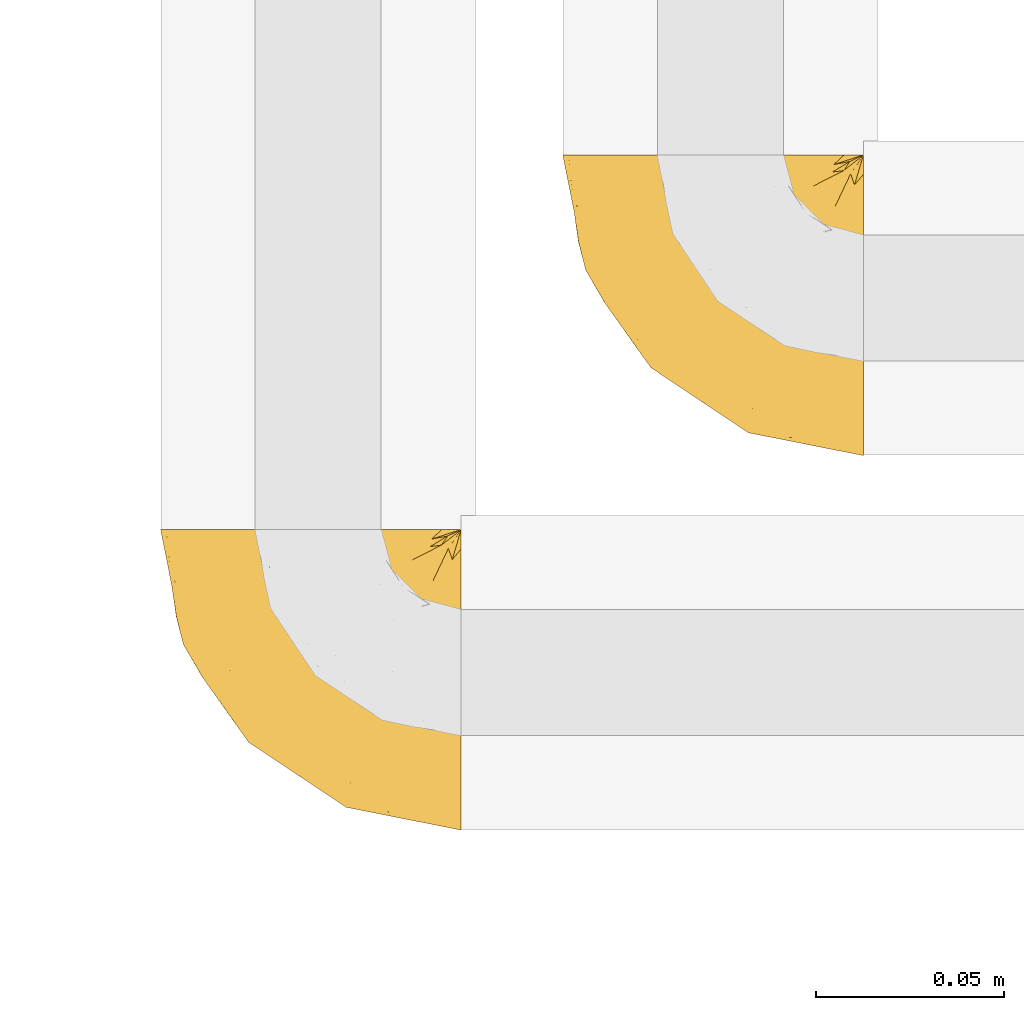
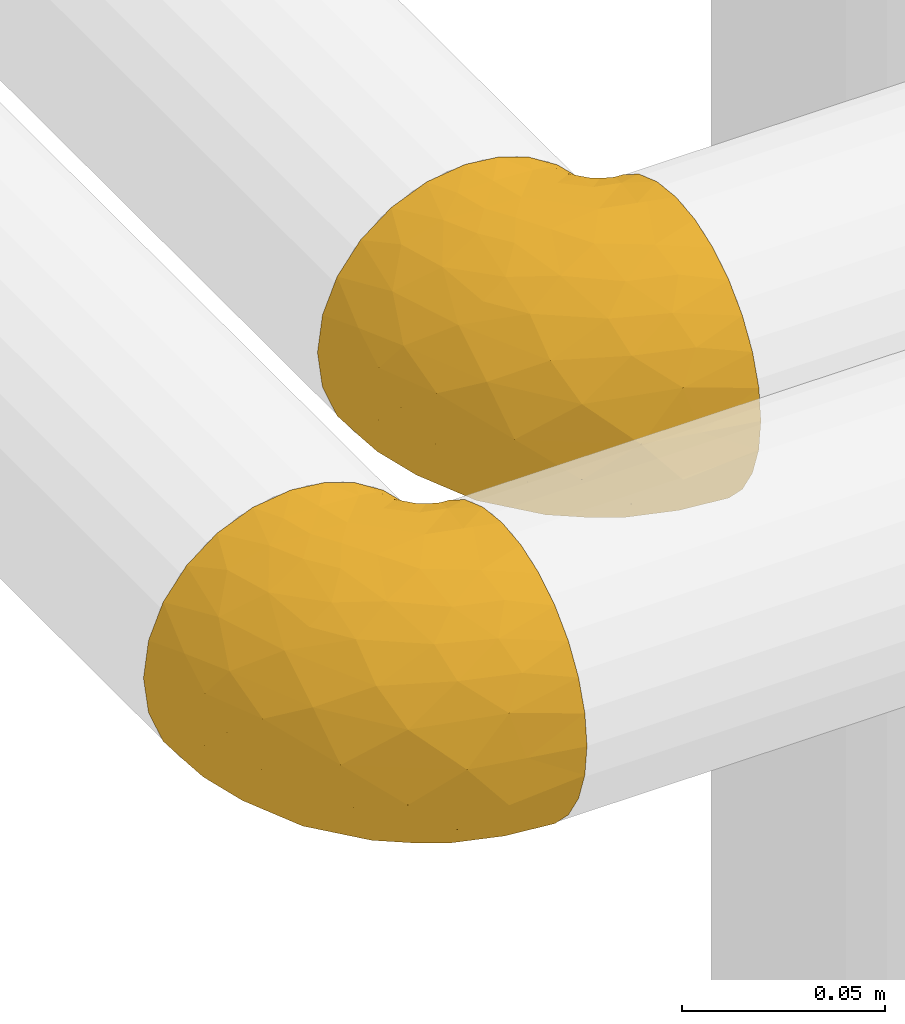
# One storey, part 351 of 827: 2 coverings.
"""IFC2X3 building model written with IfcOpenShell, lengths in millimetres."""

from ifc_helpers import new_model, entity, si_unit, converted_unit, derived_unit, direction, frame, origin, place, context, subcontext, project, spatial, faceted_brep, element, save


model = new_model("IFC2X3")

# Units and contexts
model_context = context("Model", 3, precision=0.01, world=origin(), true_north=direction((6.12303176911189e-17, 1.0)))
body_context = subcontext(model_context, "Body", "Model", "MODEL_VIEW")
ifc_project = project(units=[si_unit("LENGTHUNIT", "METRE", prefix="MILLI"), si_unit("AREAUNIT", "SQUARE_METRE"), si_unit("VOLUMEUNIT", "CUBIC_METRE"), converted_unit("PLANEANGLEUNIT", "DEGREE", entity("IfcRatioMeasure", 0.0174532925199433), si_unit("PLANEANGLEUNIT", "RADIAN"), dimensions=[0, 0, 0, 0, 0, 0, 0]), si_unit("MASSUNIT", "GRAM", prefix="KILO"), derived_unit("MASSDENSITYUNIT", [(si_unit("MASSUNIT", "GRAM", prefix="KILO"), 1), (si_unit("LENGTHUNIT", "METRE"), -3)]), derived_unit("MOMENTOFINERTIAUNIT", [(si_unit("LENGTHUNIT", "METRE"), 4)]), si_unit("TIMEUNIT", "SECOND"), si_unit("FREQUENCYUNIT", "HERTZ"), si_unit("THERMODYNAMICTEMPERATUREUNIT", "DEGREE_CELSIUS"), derived_unit("THERMALTRANSMITTANCEUNIT", [(si_unit("MASSUNIT", "GRAM", prefix="KILO"), 1), (si_unit("THERMODYNAMICTEMPERATUREUNIT", "KELVIN"), -1), (si_unit("TIMEUNIT", "SECOND"), -3)]), derived_unit("VOLUMETRICFLOWRATEUNIT", [(si_unit("LENGTHUNIT", "METRE"), 3), (si_unit("TIMEUNIT", "SECOND"), -1)]), derived_unit("MASSFLOWRATEUNIT", [(si_unit("MASSUNIT", "GRAM", prefix="KILO"), 1), (si_unit("TIMEUNIT", "SECOND"), -1)]), derived_unit("ROTATIONALFREQUENCYUNIT", [(si_unit("TIMEUNIT", "SECOND"), -1)]), si_unit("ELECTRICCURRENTUNIT", "AMPERE"), si_unit("ELECTRICVOLTAGEUNIT", "VOLT"), si_unit("POWERUNIT", "WATT"), si_unit("FORCEUNIT", "NEWTON", prefix="KILO"), si_unit("ILLUMINANCEUNIT", "LUX"), si_unit("LUMINOUSFLUXUNIT", "LUMEN"), si_unit("LUMINOUSINTENSITYUNIT", "CANDELA"), derived_unit("USERDEFINED", [(si_unit("MASSUNIT", "GRAM", prefix="KILO"), -1), (si_unit("LENGTHUNIT", "METRE"), -2), (si_unit("TIMEUNIT", "SECOND"), 3), (si_unit("LUMINOUSFLUXUNIT", "LUMEN"), 1)]), derived_unit("LINEARVELOCITYUNIT", [(si_unit("LENGTHUNIT", "METRE"), 1), (si_unit("TIMEUNIT", "SECOND"), -1)]), si_unit("PRESSUREUNIT", "PASCAL"), derived_unit("USERDEFINED", [(si_unit("LENGTHUNIT", "METRE"), -2), (si_unit("MASSUNIT", "GRAM", prefix="KILO"), 1), (si_unit("TIMEUNIT", "SECOND"), -2)]), derived_unit("LINEARFORCEUNIT", [(si_unit("MASSUNIT", "GRAM", prefix="KILO"), 1), (si_unit("LENGTHUNIT", "METRE"), 1), (si_unit("TIMEUNIT", "SECOND"), -2), (si_unit("LENGTHUNIT", "METRE"), -1)]), derived_unit("PLANARFORCEUNIT", [(si_unit("MASSUNIT", "GRAM", prefix="KILO"), 1), (si_unit("LENGTHUNIT", "METRE"), 1), (si_unit("TIMEUNIT", "SECOND"), -2), (si_unit("LENGTHUNIT", "METRE"), -2)])], contexts=[model_context])

# Site, building, storey
site_placement = place(None, origin())
site = spatial("IfcSite", under=ifc_project, at=site_placement, CompositionType="ELEMENT")
building_placement = place(site_placement, origin())
building = spatial("IfcBuilding", under=site, at=building_placement, CompositionType="ELEMENT")
storey_placement = place(building_placement, frame((0.0, 0.0, 28200.0)))
storey = spatial("IfcBuildingStorey", under=building, at=storey_placement, Name="08", CompositionType="ELEMENT", Elevation=28200.0)

# Coverings
covering_1_placement = place(storey_placement, frame((41432.77, 15288.87, 2956.55)))
element("IfcCovering", 1, at=covering_1_placement, inside=storey, Name=":ADSK_", ObjectType=":ADSK_", PredefinedType="INSULATION", context=body_context, shape_type="Brep", body=[
    faceted_brep([(81.45, 25.28, 81.15), (81.45, 17.35, 76.16), (81.45, 10.72, 69.53), (81.45, 5.74, 61.6), (81.45, 2.64, 52.75), (81.45, 1.6, 43.45), (81.45, 2.65, 34.13), (81.45, 5.74, 25.28), (81.45, 10.73, 17.35), (81.45, 17.36, 10.72), (81.45, 25.29, 5.74), (81.45, 34.14, 2.64), (81.45, 43.45, 1.6), (81.45, 52.82, 2.66), (81.45, 61.71, 5.79), (81.45, 69.67, 10.83), (81.45, 76.31, 17.53), (81.45, 81.27, 25.53), (81.45, 81.27, 26.45), (81.45, 81.27, 27.37), (81.45, 81.27, 28.17), (81.45, 81.27, 29.49), (81.45, 81.27, 30.81), (81.45, 81.27, 32.13), (81.45, 81.27, 33.45), (81.45, 81.27, 34.78), (81.45, 81.27, 36.1), (81.45, 81.27, 37.42), (81.45, 81.27, 38.74), (81.45, 81.27, 40.06), (81.45, 81.27, 41.38), (81.45, 81.27, 42.7), (81.45, 81.27, 44.02), (81.45, 81.27, 45.34), (81.45, 81.27, 46.66), (81.45, 81.27, 47.58), (81.45, 81.27, 48.5), (81.45, 81.27, 49.41), (81.45, 81.27, 50.33), (81.45, 81.27, 51.25), (81.45, 81.27, 52.17), (81.45, 81.27, 53.09), (81.45, 81.27, 54.01), (81.45, 81.27, 54.93), (81.45, 81.27, 55.85), (81.45, 81.27, 56.76), (81.45, 81.27, 57.68), (81.45, 81.27, 58.6), (81.45, 81.27, 59.52), (81.45, 81.27, 60.44), (81.45, 81.27, 61.36), (81.45, 76.3, 69.37), (81.45, 69.66, 76.07), (81.45, 61.69, 81.11), (81.45, 52.8, 84.24), (81.45, 43.45, 85.3), (81.45, 34.13, 84.24), (76.3, 81.45, 17.52), (69.67, 81.45, 10.83), (61.7, 81.45, 5.79), (52.81, 81.45, 2.66), (43.45, 81.45, 1.6), (32.61, 81.45, 3.02), (22.52, 81.45, 7.2), (13.85, 81.45, 13.85), (7.2, 81.45, 22.52), (3.02, 81.45, 32.61), (1.6, 81.45, 43.45), (3.02, 81.45, 54.28), (7.2, 81.45, 64.37), (13.85, 81.45, 73.04), (22.52, 81.45, 79.69), (32.61, 81.45, 83.87), (43.45, 81.45, 85.3), (52.81, 81.45, 84.23), (61.7, 81.45, 81.1), (69.67, 81.45, 76.06), (76.3, 81.45, 69.37), (81.27, 81.45, 61.36), (81.27, 81.45, 60.44), (81.27, 81.45, 59.12), (81.27, 81.45, 58.0), (81.27, 81.45, 56.88), (81.27, 81.45, 55.76), (81.27, 81.45, 54.64), (81.27, 81.45, 53.52), (81.27, 81.45, 52.4), (81.27, 81.45, 51.28), (81.27, 81.45, 50.16), (81.27, 81.45, 49.04), (81.27, 81.45, 47.92), (81.27, 81.45, 46.8), (81.27, 81.45, 45.68), (81.27, 81.45, 44.56), (81.27, 81.45, 43.45), (81.27, 81.45, 42.12), (81.27, 81.45, 40.8), (81.27, 81.45, 39.48), (81.27, 81.45, 38.16), (81.27, 81.45, 36.84), (81.27, 81.45, 35.52), (81.27, 81.45, 34.2), (81.27, 81.45, 32.88), (81.27, 81.45, 31.96), (81.27, 81.45, 31.05), (81.27, 81.45, 30.13), (81.27, 81.45, 29.21), (81.27, 81.45, 28.29), (81.27, 81.45, 27.37), (81.27, 81.45, 26.45), (81.27, 81.45, 25.53), (81.31, 81.33, 54.08), (81.33, 81.32, 55.16), (81.31, 81.33, 36.18), (81.32, 81.32, 35.13), (81.31, 81.33, 44.01), (81.32, 81.32, 45.08), (81.32, 81.32, 61.36), (81.32, 81.32, 59.98), (81.32, 81.32, 46.18), (81.32, 81.32, 26.74), (81.32, 81.32, 47.36), (81.32, 81.32, 29.67), (81.3, 81.34, 28.72), (81.32, 81.32, 39.77), (81.33, 81.31, 52.96), (81.31, 81.33, 51.84), (81.33, 81.31, 40.8), (81.32, 81.32, 41.87), (81.32, 81.33, 42.94), (81.32, 81.32, 27.77), (81.31, 81.33, 48.4), (81.32, 81.32, 37.21), (81.31, 81.33, 33.54), (81.32, 81.32, 32.49), (81.32, 81.32, 30.69), (81.32, 81.32, 50.69), (81.33, 81.31, 49.6), (81.32, 81.32, 56.32), (81.31, 81.33, 57.44), (81.33, 81.31, 58.88), (81.32, 81.32, 25.53), (81.36, 81.3, 61.36), (81.4, 81.29, 61.36), (81.4, 81.29, 25.53), (81.36, 81.3, 25.53), (81.29, 81.4, 61.36), (81.3, 81.36, 61.36), (81.3, 81.36, 25.53), (81.29, 81.4, 25.53), (81.35, 81.3, 31.59), (81.31, 81.33, 38.71), (58.5, 74.06, 3.97), (71.95, 45.99, 1.6), (74.57, 58.35, 3.97), (73.93, 67.76, 8.09), (78.18, 66.18, 8.09), (78.04, 76.46, 16.43), (76.23, 77.33, 15.73), (45.99, 71.95, 1.6), (74.01, 72.25, 10.79), (73.57, 78.91, 13.99), (66.66, 76.42, 8.08), (79.09, 73.52, 14.0), (73.14, 76.9, 12.83), (60.34, 65.25, 3.18), (48.54, 62.45, 1.6), (45.36, 74.31, 1.6), (67.22, 59.38, 3.28), (62.45, 48.54, 1.6), (68.67, 67.72, 6.28), (55.49, 55.49, 1.6), (77.84, 79.73, 19.06), (68.16, 73.23, 8.08), (74.31, 45.36, 1.6), (38.78, 15.81, 32.11), (62.1, 6.4, 29.62), (50.89, 7.67, 43.45), (36.91, 68.46, 2.45), (40.37, 59.33, 2.5), (27.86, 48.7, 9.73), (15.77, 53.94, 17.97), (20.13, 65.02, 10.24), (31.54, 60.77, 4.78), (28.25, 72.07, 4.78), (57.26, 26.25, 8.01), (69.99, 22.29, 8.01), (64.58, 16.0, 13.85), (50.64, 46.93, 2.42), (51.97, 14.19, 21.17), (5.72, 58.46, 35.73), (7.42, 61.51, 27.43), (66.14, 4.64, 43.45), (11.35, 68.93, 17.97), (21.64, 29.62, 35.71), (28.57, 24.85, 29.47), (55.38, 38.55, 3.41), (68.51, 31.27, 3.94), (67.48, 9.35, 21.17), (40.78, 37.15, 7.92), (41.53, 47.07, 4.25), (46.11, 26.49, 11.75), (40.32, 23.01, 18.31), (38.36, 19.4, 24.94), (11.84, 48.06, 28.78), (12.56, 42.46, 35.82), (7.67, 50.89, 43.45), (19.39, 35.78, 28.38), (24.98, 24.98, 43.45), (37.94, 16.33, 43.45), (4.64, 66.14, 43.45), (28.09, 30.96, 21.21), (23.73, 41.83, 16.48), (34.03, 33.28, 13.85), (16.33, 37.94, 43.45), (29.29, 67.39, 82.11), (5.77, 58.47, 51.41), (21.44, 32.5, 57.45), (38.8, 15.79, 54.78), (64.58, 15.99, 73.03), (67.49, 9.34, 65.7), (22.9, 56.91, 76.65), (12.54, 63.5, 68.92), (20.04, 44.08, 68.01), (57.26, 26.24, 78.88), (69.99, 22.27, 78.88), (68.51, 31.26, 82.94), (34.54, 23.95, 64.44), (38.81, 63.79, 84.49), (48.54, 62.45, 85.3), (45.99, 71.95, 85.3), (74.31, 45.36, 85.3), (5.36, 67.83, 57.84), (18.96, 70.28, 76.65), (12.79, 42.11, 51.19), (62.11, 6.39, 57.26), (33.14, 43.54, 78.14), (33.44, 58.03, 82.35), (51.98, 14.18, 65.7), (43.42, 56.34, 84.61), (48.62, 48.09, 84.36), (62.45, 48.54, 85.3), (55.49, 55.49, 85.3), (49.68, 21.78, 73.03), (55.37, 38.54, 83.48), (71.95, 45.99, 85.3), (36.37, 72.79, 84.54), (34.04, 33.26, 73.03), (44.1, 35.53, 79.54), (9.99, 53.66, 59.46), (26.41, 43.03, 73.5), (39.19, 49.68, 82.57), (58.5, 74.06, 82.92), (67.22, 59.37, 83.62), (74.57, 58.34, 82.92), (73.92, 67.75, 78.81), (73.57, 78.91, 72.9), (73.14, 76.9, 74.06), (66.19, 78.08, 78.81), (68.16, 73.23, 78.81), (77.84, 79.73, 67.83), (76.23, 77.34, 71.15), (79.08, 73.51, 72.91), (78.04, 76.45, 70.47), (77.18, 66.41, 78.81), (68.66, 67.7, 80.62), (74.0, 72.24, 76.11), (60.34, 65.25, 83.71)], [[[0, 1, 2, 3, 4, 5, 6, 7, 8, 9, 10, 11, 12, 13, 14, 15, 16, 17, 18, 19, 20, 21, 22, 23, 24, 25, 26, 27, 28, 29, 30, 31, 32, 33, 34, 35, 36, 37, 38, 39, 40, 41, 42, 43, 44, 45, 46, 47, 48, 49, 50, 51, 52, 53, 54, 55, 56]], [[57, 58, 59, 60, 61, 62, 63, 64, 65, 66, 67, 68, 69, 70, 71, 72, 73, 74, 75, 76, 77, 78, 79, 80, 81, 82, 83, 84, 85, 86, 87, 88, 89, 90, 91, 92, 93, 94, 95, 96, 97, 98, 99, 100, 101, 102, 103, 104, 105, 106, 107, 108, 109, 110]], [[111, 84, 112]], [[113, 26, 114]], [[114, 101, 100]], [[115, 93, 116]], [[79, 117, 118]], [[33, 116, 119]], [[117, 49, 118]], [[19, 18, 120]], [[119, 121, 34]], [[122, 21, 123]], [[97, 96, 124]], [[86, 125, 126]], [[116, 92, 119]], [[127, 96, 128]], [[32, 129, 115]], [[19, 120, 130]], [[121, 90, 131]], [[94, 115, 129]], [[115, 116, 32]], [[118, 49, 48]], [[113, 99, 132]], [[133, 114, 25]], [[24, 134, 133]], [[135, 22, 122]], [[136, 137, 88]], [[84, 83, 112]], [[138, 82, 139]], [[130, 20, 19]], [[118, 48, 140]], [[81, 140, 139]], [[123, 21, 20]], [[141, 120, 18]], [[139, 82, 81]], [[130, 107, 123]], [[49, 117, 142, 143, 50]], [[18, 17, 144, 145, 141]], [[79, 78, 146, 147, 117]], [[109, 141, 148, 149, 110]], [[102, 133, 134]], [[105, 135, 122]], [[118, 80, 79]], [[120, 109, 108]], [[80, 118, 140]], [[47, 46, 140, 48]], [[81, 80, 140]], [[44, 112, 138]], [[93, 115, 94]], [[46, 139, 140]], [[46, 45, 139]], [[139, 45, 138]], [[138, 112, 83]], [[85, 84, 111]], [[112, 43, 111]], [[83, 82, 138]], [[106, 122, 123]], [[105, 122, 106]], [[21, 122, 22]], [[124, 29, 28]], [[33, 32, 116]], [[128, 129, 31]], [[32, 31, 129]], [[34, 33, 119]], [[116, 93, 92]], [[129, 95, 94]], [[95, 129, 128]], [[41, 40, 125, 42]], [[119, 91, 121]], [[36, 35, 131, 37]], [[137, 131, 89]], [[121, 131, 35]], [[90, 121, 91]], [[119, 92, 91]], [[136, 126, 39]], [[125, 86, 85]], [[42, 125, 111]], [[85, 111, 125]], [[150, 23, 22]], [[130, 108, 107]], [[130, 123, 20]], [[107, 106, 123]], [[137, 37, 131]], [[136, 38, 137]], [[89, 88, 137]], [[131, 90, 89]], [[124, 151, 97]], [[40, 39, 126]], [[87, 126, 136]], [[86, 126, 87]], [[136, 88, 87]], [[40, 126, 125]], [[39, 38, 136]], [[95, 128, 96]], [[30, 128, 31]], [[29, 124, 127]], [[127, 128, 30]], [[151, 124, 28]], [[127, 30, 29]], [[127, 124, 96]], [[151, 98, 97]], [[45, 44, 138]], [[26, 113, 132]], [[113, 100, 99]], [[132, 151, 27]], [[27, 26, 132]], [[26, 25, 114]], [[100, 113, 114]], [[101, 133, 102]], [[133, 101, 114]], [[28, 27, 151]], [[132, 99, 98]], [[23, 134, 24]], [[25, 24, 133]], [[134, 23, 150]], [[135, 104, 150]], [[150, 104, 103]], [[103, 102, 134]], [[130, 120, 108]], [[109, 120, 141]], [[42, 111, 43]], [[112, 44, 43]], [[104, 135, 105]], [[134, 150, 103]], [[135, 150, 22]], [[35, 34, 121]], [[137, 38, 37]], [[98, 151, 132]], [[59, 152, 60]], [[13, 153, 154]], [[155, 156, 154]], [[157, 158, 141]], [[159, 60, 152]], [[160, 157, 155]], [[161, 162, 58]], [[58, 162, 59]], [[144, 16, 163]], [[58, 57, 161]], [[162, 161, 164]], [[157, 163, 155]], [[163, 16, 15]], [[57, 149, 161]], [[152, 165, 166]], [[157, 144, 163]], [[60, 159, 167, 61]], [[156, 14, 154]], [[163, 156, 155]], [[155, 154, 168]], [[168, 154, 169]], [[155, 170, 160]], [[57, 110, 149]], [[144, 17, 16]], [[156, 15, 14]], [[171, 165, 168]], [[158, 164, 172]], [[14, 13, 154]], [[157, 141, 145, 144]], [[173, 164, 158]], [[173, 160, 170]], [[171, 166, 165]], [[168, 165, 170]], [[168, 169, 171]], [[152, 173, 165]], [[170, 155, 168]], [[165, 173, 170]], [[160, 173, 158]], [[172, 149, 148]], [[148, 141, 158]], [[158, 157, 160]], [[152, 166, 159]], [[173, 152, 162]], [[59, 162, 152]], [[13, 12, 174, 153]], [[153, 169, 154]], [[15, 156, 163]], [[162, 164, 173]], [[172, 164, 161]], [[149, 172, 161]], [[158, 172, 148]], [[175, 176, 177]], [[178, 166, 179]], [[180, 181, 182]], [[183, 184, 178]], [[185, 186, 187]], [[171, 188, 179]], [[174, 12, 11]], [[189, 176, 175]], [[190, 66, 191]], [[176, 6, 192]], [[193, 65, 64]], [[63, 184, 182]], [[63, 182, 64]], [[65, 193, 191]], [[184, 63, 62]], [[175, 194, 195]], [[196, 169, 197]], [[174, 11, 197]], [[8, 7, 198]], [[187, 9, 8]], [[197, 169, 153, 174]], [[197, 11, 10]], [[186, 197, 10]], [[199, 180, 200]], [[197, 185, 196]], [[201, 189, 202]], [[201, 187, 189]], [[195, 203, 175]], [[191, 204, 190]], [[176, 7, 6]], [[177, 176, 192]], [[189, 198, 176]], [[65, 191, 66]], [[198, 187, 8]], [[205, 206, 190]], [[9, 186, 10]], [[181, 207, 204]], [[208, 175, 177, 209]], [[66, 190, 210]], [[211, 212, 213]], [[190, 204, 205]], [[180, 182, 183]], [[193, 182, 181]], [[62, 61, 167]], [[196, 185, 199]], [[196, 200, 188]], [[6, 5, 192]], [[176, 198, 7]], [[187, 198, 189]], [[187, 186, 9]], [[197, 186, 185]], [[200, 180, 183]], [[180, 213, 212]], [[179, 183, 178]], [[185, 201, 199]], [[210, 190, 206]], [[210, 67, 66]], [[205, 204, 207]], [[194, 205, 207]], [[194, 214, 205]], [[195, 194, 207]], [[208, 194, 175]], [[207, 211, 195]], [[202, 203, 211]], [[212, 207, 181]], [[202, 211, 213]], [[201, 202, 213]], [[189, 175, 203]], [[199, 201, 213]], [[187, 201, 185]], [[180, 199, 213]], [[196, 199, 200]], [[211, 203, 195]], [[189, 203, 202]], [[207, 212, 211]], [[180, 212, 181]], [[214, 194, 208]], [[214, 206, 205]], [[196, 188, 169]], [[181, 204, 191]], [[182, 193, 64]], [[191, 193, 181]], [[178, 62, 167]], [[182, 184, 183]], [[62, 178, 184]], [[178, 167, 159, 166]], [[171, 179, 166]], [[200, 183, 179]], [[179, 188, 200]], [[169, 188, 171]], [[71, 215, 72]], [[206, 216, 210]], [[217, 208, 218]], [[216, 68, 210]], [[219, 220, 2]], [[221, 222, 223]], [[224, 225, 226]], [[227, 223, 217]], [[228, 229, 230]], [[56, 231, 226]], [[232, 222, 69]], [[56, 55, 231]], [[70, 233, 71]], [[71, 233, 215]], [[0, 56, 226]], [[208, 217, 234]], [[218, 177, 235]], [[221, 236, 237]], [[238, 220, 219]], [[1, 219, 2]], [[68, 216, 232]], [[235, 3, 220]], [[235, 192, 4]], [[1, 0, 225]], [[228, 239, 229]], [[240, 241, 242]], [[243, 238, 219]], [[224, 226, 244]], [[226, 241, 244]], [[3, 235, 4]], [[69, 222, 70]], [[225, 219, 1]], [[218, 235, 238]], [[243, 219, 224]], [[218, 227, 217]], [[3, 2, 220]], [[218, 208, 209, 177]], [[226, 231, 245, 241]], [[215, 228, 246]], [[247, 248, 236]], [[248, 224, 244]], [[223, 222, 249]], [[233, 222, 221]], [[242, 239, 240]], [[248, 247, 243]], [[217, 223, 249]], [[250, 247, 236]], [[216, 234, 249]], [[218, 238, 227]], [[192, 235, 177]], [[192, 5, 4]], [[72, 246, 73]], [[235, 220, 238]], [[226, 225, 0]], [[219, 225, 224]], [[240, 248, 244]], [[239, 242, 229]], [[236, 248, 251]], [[68, 67, 210]], [[234, 216, 206]], [[216, 249, 232]], [[234, 206, 214, 208]], [[249, 234, 217]], [[222, 232, 249]], [[69, 68, 232]], [[246, 228, 230]], [[237, 228, 215]], [[243, 227, 238]], [[223, 227, 247]], [[73, 246, 230]], [[215, 246, 72]], [[248, 243, 224]], [[227, 243, 247]], [[237, 236, 251]], [[250, 221, 223]], [[222, 233, 70]], [[215, 233, 221]], [[221, 237, 215]], [[239, 237, 251]], [[237, 239, 228]], [[239, 251, 240]], [[248, 240, 251]], [[241, 240, 244]], [[221, 250, 236]], [[223, 247, 250]], [[74, 230, 252]], [[253, 254, 255]], [[146, 77, 256]], [[257, 258, 259]], [[260, 256, 257]], [[260, 261, 147]], [[75, 74, 252]], [[51, 143, 262]], [[263, 143, 142, 117]], [[256, 77, 76]], [[252, 258, 75]], [[253, 241, 254]], [[254, 245, 54]], [[258, 256, 76]], [[53, 52, 264]], [[255, 265, 253]], [[254, 264, 255]], [[255, 264, 262]], [[75, 258, 76]], [[265, 255, 266]], [[255, 262, 263]], [[51, 50, 143]], [[54, 245, 231, 55]], [[51, 262, 52]], [[253, 267, 242]], [[254, 54, 53]], [[266, 259, 265]], [[146, 78, 77]], [[263, 117, 261]], [[146, 256, 260]], [[257, 259, 261]], [[267, 253, 265]], [[229, 267, 252]], [[242, 267, 229]], [[242, 241, 253]], [[252, 267, 259]], [[255, 263, 266]], [[259, 267, 265]], [[261, 117, 147]], [[263, 261, 266]], [[259, 266, 261]], [[230, 74, 73]], [[230, 229, 252]], [[259, 258, 252]], [[254, 241, 245]], [[53, 264, 254]], [[52, 262, 264]], [[143, 263, 262]], [[258, 257, 256]], [[261, 260, 257]], [[146, 260, 147]]]),
])
covering_2_placement = place(storey_placement, frame((41325.93, 15189.39, 2956.55)))
element("IfcCovering", 2, at=covering_2_placement, inside=storey, Name=":ADSK_", ObjectType=":ADSK_", PredefinedType="INSULATION", context=body_context, shape_type="Brep", body=[
    faceted_brep([(81.45, 25.28, 81.15), (81.45, 17.35, 76.16), (81.45, 10.72, 69.53), (81.45, 5.74, 61.6), (81.45, 2.64, 52.75), (81.45, 1.6, 43.45), (81.45, 2.65, 34.13), (81.45, 5.74, 25.28), (81.45, 10.73, 17.35), (81.45, 17.36, 10.72), (81.45, 25.29, 5.74), (81.45, 34.14, 2.64), (81.45, 43.45, 1.6), (81.45, 52.82, 2.66), (81.45, 61.71, 5.79), (81.45, 69.67, 10.83), (81.45, 76.31, 17.53), (81.45, 81.27, 25.53), (81.45, 81.27, 26.45), (81.45, 81.27, 27.37), (81.45, 81.27, 28.17), (81.45, 81.27, 29.49), (81.45, 81.27, 30.81), (81.45, 81.27, 32.13), (81.45, 81.27, 33.45), (81.45, 81.27, 34.78), (81.45, 81.27, 36.1), (81.45, 81.27, 37.42), (81.45, 81.27, 38.74), (81.45, 81.27, 40.06), (81.45, 81.27, 41.38), (81.45, 81.27, 42.7), (81.45, 81.27, 44.02), (81.45, 81.27, 45.34), (81.45, 81.27, 46.66), (81.45, 81.27, 47.58), (81.45, 81.27, 48.5), (81.45, 81.27, 49.41), (81.45, 81.27, 50.33), (81.45, 81.27, 51.25), (81.45, 81.27, 52.17), (81.45, 81.27, 53.09), (81.45, 81.27, 54.01), (81.45, 81.27, 54.93), (81.45, 81.27, 55.85), (81.45, 81.27, 56.76), (81.45, 81.27, 57.68), (81.45, 81.27, 58.6), (81.45, 81.27, 59.52), (81.45, 81.27, 60.44), (81.45, 81.27, 61.36), (81.45, 76.3, 69.37), (81.45, 69.66, 76.07), (81.45, 61.69, 81.11), (81.45, 52.8, 84.24), (81.45, 43.45, 85.3), (81.45, 34.13, 84.24), (76.3, 81.45, 17.52), (69.67, 81.45, 10.83), (61.7, 81.45, 5.79), (52.81, 81.45, 2.66), (43.45, 81.45, 1.6), (32.61, 81.45, 3.02), (22.52, 81.45, 7.2), (13.85, 81.45, 13.85), (7.2, 81.45, 22.52), (3.02, 81.45, 32.61), (1.6, 81.45, 43.45), (3.02, 81.45, 54.28), (7.2, 81.45, 64.37), (13.85, 81.45, 73.04), (22.52, 81.45, 79.69), (32.61, 81.45, 83.87), (43.45, 81.45, 85.3), (52.81, 81.45, 84.23), (61.7, 81.45, 81.1), (69.67, 81.45, 76.06), (76.3, 81.45, 69.37), (81.27, 81.45, 61.36), (81.27, 81.45, 60.44), (81.27, 81.45, 59.12), (81.27, 81.45, 58.0), (81.27, 81.45, 56.88), (81.27, 81.45, 55.76), (81.27, 81.45, 54.64), (81.27, 81.45, 53.52), (81.27, 81.45, 52.4), (81.27, 81.45, 51.28), (81.27, 81.45, 50.16), (81.27, 81.45, 49.04), (81.27, 81.45, 47.92), (81.27, 81.45, 46.8), (81.27, 81.45, 45.68), (81.27, 81.45, 44.56), (81.27, 81.45, 43.45), (81.27, 81.45, 42.12), (81.27, 81.45, 40.8), (81.27, 81.45, 39.48), (81.27, 81.45, 38.16), (81.27, 81.45, 36.84), (81.27, 81.45, 35.52), (81.27, 81.45, 34.2), (81.27, 81.45, 32.88), (81.27, 81.45, 31.96), (81.27, 81.45, 31.05), (81.27, 81.45, 30.13), (81.27, 81.45, 29.21), (81.27, 81.45, 28.29), (81.27, 81.45, 27.37), (81.27, 81.45, 26.45), (81.27, 81.45, 25.53), (81.31, 81.33, 54.08), (81.33, 81.32, 55.16), (81.31, 81.33, 36.18), (81.32, 81.32, 35.13), (81.31, 81.33, 44.01), (81.32, 81.32, 45.08), (81.32, 81.32, 61.36), (81.32, 81.32, 59.98), (81.32, 81.32, 46.18), (81.32, 81.32, 26.74), (81.32, 81.32, 47.36), (81.32, 81.32, 29.67), (81.3, 81.34, 28.72), (81.32, 81.32, 39.77), (81.33, 81.31, 52.96), (81.31, 81.33, 51.84), (81.33, 81.31, 40.8), (81.32, 81.32, 41.87), (81.32, 81.33, 42.94), (81.32, 81.32, 27.77), (81.31, 81.33, 48.4), (81.32, 81.32, 37.21), (81.31, 81.33, 33.54), (81.32, 81.32, 32.49), (81.32, 81.32, 30.69), (81.32, 81.32, 50.69), (81.33, 81.31, 49.6), (81.32, 81.32, 56.32), (81.31, 81.33, 57.44), (81.33, 81.31, 58.88), (81.32, 81.32, 25.53), (81.36, 81.3, 61.36), (81.4, 81.29, 61.36), (81.4, 81.29, 25.53), (81.36, 81.3, 25.53), (81.29, 81.4, 61.36), (81.3, 81.36, 61.36), (81.3, 81.36, 25.53), (81.29, 81.4, 25.53), (81.35, 81.3, 31.59), (81.31, 81.33, 38.71), (58.5, 74.06, 3.97), (71.95, 45.99, 1.6), (74.57, 58.35, 3.97), (73.93, 67.76, 8.09), (78.18, 66.18, 8.09), (78.04, 76.46, 16.43), (76.23, 77.33, 15.73), (45.99, 71.95, 1.6), (74.01, 72.25, 10.79), (73.57, 78.91, 13.99), (66.66, 76.42, 8.08), (79.09, 73.52, 14.0), (73.14, 76.9, 12.83), (60.34, 65.25, 3.18), (48.54, 62.45, 1.6), (45.36, 74.31, 1.6), (67.22, 59.38, 3.28), (62.45, 48.54, 1.6), (68.67, 67.72, 6.28), (55.49, 55.49, 1.6), (77.84, 79.73, 19.06), (68.16, 73.23, 8.08), (74.31, 45.36, 1.6), (38.78, 15.81, 32.11), (62.1, 6.4, 29.62), (50.89, 7.67, 43.45), (36.91, 68.46, 2.45), (40.37, 59.33, 2.5), (27.86, 48.7, 9.73), (15.77, 53.94, 17.97), (20.13, 65.02, 10.24), (31.54, 60.77, 4.78), (28.25, 72.07, 4.78), (57.26, 26.25, 8.01), (69.99, 22.29, 8.01), (64.58, 16.0, 13.85), (50.64, 46.93, 2.42), (51.97, 14.19, 21.17), (5.72, 58.46, 35.73), (7.42, 61.51, 27.43), (66.14, 4.64, 43.45), (11.35, 68.93, 17.97), (21.64, 29.62, 35.71), (28.57, 24.85, 29.47), (55.38, 38.55, 3.41), (68.51, 31.27, 3.94), (67.48, 9.35, 21.17), (40.78, 37.15, 7.92), (41.53, 47.07, 4.25), (46.11, 26.49, 11.75), (40.32, 23.01, 18.31), (38.36, 19.4, 24.94), (11.84, 48.06, 28.78), (12.56, 42.46, 35.82), (7.67, 50.89, 43.45), (19.39, 35.78, 28.38), (24.98, 24.98, 43.45), (37.94, 16.33, 43.45), (4.64, 66.14, 43.45), (28.09, 30.96, 21.21), (23.73, 41.83, 16.48), (34.03, 33.28, 13.85), (16.33, 37.94, 43.45), (29.29, 67.39, 82.11), (5.77, 58.47, 51.41), (21.44, 32.5, 57.45), (38.8, 15.79, 54.78), (64.58, 15.99, 73.03), (67.49, 9.34, 65.7), (22.9, 56.91, 76.65), (12.54, 63.5, 68.92), (20.04, 44.08, 68.01), (57.26, 26.24, 78.88), (69.99, 22.27, 78.88), (68.51, 31.26, 82.94), (34.54, 23.95, 64.44), (38.81, 63.79, 84.49), (48.54, 62.45, 85.3), (45.99, 71.95, 85.3), (74.31, 45.36, 85.3), (5.36, 67.83, 57.84), (18.96, 70.28, 76.65), (12.79, 42.11, 51.19), (62.11, 6.39, 57.26), (33.14, 43.54, 78.14), (33.44, 58.03, 82.35), (51.98, 14.18, 65.7), (43.42, 56.34, 84.61), (48.62, 48.09, 84.36), (62.45, 48.54, 85.3), (55.49, 55.49, 85.3), (49.68, 21.78, 73.03), (55.37, 38.54, 83.48), (71.95, 45.99, 85.3), (36.37, 72.79, 84.54), (34.04, 33.26, 73.03), (44.1, 35.53, 79.54), (9.99, 53.66, 59.46), (26.41, 43.03, 73.5), (39.19, 49.68, 82.57), (58.5, 74.06, 82.92), (67.22, 59.37, 83.62), (74.57, 58.34, 82.92), (73.92, 67.75, 78.81), (73.57, 78.91, 72.9), (73.14, 76.9, 74.06), (66.19, 78.08, 78.81), (68.16, 73.23, 78.81), (77.84, 79.73, 67.83), (76.23, 77.34, 71.15), (79.08, 73.51, 72.91), (78.04, 76.45, 70.47), (77.18, 66.41, 78.81), (68.66, 67.7, 80.62), (74.0, 72.24, 76.11), (60.34, 65.25, 83.71)], [[[0, 1, 2, 3, 4, 5, 6, 7, 8, 9, 10, 11, 12, 13, 14, 15, 16, 17, 18, 19, 20, 21, 22, 23, 24, 25, 26, 27, 28, 29, 30, 31, 32, 33, 34, 35, 36, 37, 38, 39, 40, 41, 42, 43, 44, 45, 46, 47, 48, 49, 50, 51, 52, 53, 54, 55, 56]], [[57, 58, 59, 60, 61, 62, 63, 64, 65, 66, 67, 68, 69, 70, 71, 72, 73, 74, 75, 76, 77, 78, 79, 80, 81, 82, 83, 84, 85, 86, 87, 88, 89, 90, 91, 92, 93, 94, 95, 96, 97, 98, 99, 100, 101, 102, 103, 104, 105, 106, 107, 108, 109, 110]], [[111, 84, 112]], [[113, 26, 114]], [[114, 101, 100]], [[115, 93, 116]], [[79, 117, 118]], [[33, 116, 119]], [[117, 49, 118]], [[19, 18, 120]], [[119, 121, 34]], [[122, 21, 123]], [[97, 96, 124]], [[86, 125, 126]], [[116, 92, 119]], [[127, 96, 128]], [[32, 129, 115]], [[19, 120, 130]], [[121, 90, 131]], [[94, 115, 129]], [[115, 116, 32]], [[118, 49, 48]], [[113, 99, 132]], [[133, 114, 25]], [[24, 134, 133]], [[135, 22, 122]], [[136, 137, 88]], [[84, 83, 112]], [[138, 82, 139]], [[130, 20, 19]], [[118, 48, 140]], [[81, 140, 139]], [[123, 21, 20]], [[141, 120, 18]], [[139, 82, 81]], [[130, 107, 123]], [[49, 117, 142, 143, 50]], [[18, 17, 144, 145, 141]], [[79, 78, 146, 147, 117]], [[109, 141, 148, 149, 110]], [[102, 133, 134]], [[105, 135, 122]], [[118, 80, 79]], [[80, 118, 140]], [[120, 109, 108]], [[47, 46, 140, 48]], [[81, 80, 140]], [[44, 112, 138]], [[93, 115, 94]], [[46, 139, 140]], [[46, 45, 139]], [[139, 45, 138]], [[138, 112, 83]], [[85, 84, 111]], [[112, 43, 111]], [[83, 82, 138]], [[106, 122, 123]], [[105, 122, 106]], [[21, 122, 22]], [[124, 29, 28]], [[33, 32, 116]], [[128, 129, 31]], [[32, 31, 129]], [[34, 33, 119]], [[116, 93, 92]], [[129, 95, 94]], [[95, 129, 128]], [[41, 40, 125, 42]], [[119, 91, 121]], [[36, 35, 131, 37]], [[137, 131, 89]], [[121, 131, 35]], [[90, 121, 91]], [[119, 92, 91]], [[136, 126, 39]], [[125, 86, 85]], [[42, 125, 111]], [[85, 111, 125]], [[150, 23, 22]], [[130, 108, 107]], [[130, 123, 20]], [[107, 106, 123]], [[137, 37, 131]], [[136, 38, 137]], [[89, 88, 137]], [[131, 90, 89]], [[124, 151, 97]], [[40, 39, 126]], [[87, 126, 136]], [[86, 126, 87]], [[136, 88, 87]], [[40, 126, 125]], [[39, 38, 136]], [[95, 128, 96]], [[30, 128, 31]], [[29, 124, 127]], [[127, 128, 30]], [[151, 124, 28]], [[127, 30, 29]], [[127, 124, 96]], [[151, 98, 97]], [[45, 44, 138]], [[26, 113, 132]], [[113, 100, 99]], [[132, 151, 27]], [[27, 26, 132]], [[26, 25, 114]], [[100, 113, 114]], [[101, 133, 102]], [[133, 101, 114]], [[28, 27, 151]], [[132, 99, 98]], [[23, 134, 24]], [[25, 24, 133]], [[134, 23, 150]], [[135, 104, 150]], [[150, 104, 103]], [[103, 102, 134]], [[130, 120, 108]], [[109, 120, 141]], [[42, 111, 43]], [[112, 44, 43]], [[104, 135, 105]], [[134, 150, 103]], [[135, 150, 22]], [[35, 34, 121]], [[137, 38, 37]], [[98, 151, 132]], [[59, 152, 60]], [[13, 153, 154]], [[155, 156, 154]], [[157, 158, 141]], [[159, 60, 152]], [[160, 157, 155]], [[161, 162, 58]], [[58, 162, 59]], [[144, 16, 163]], [[58, 57, 161]], [[162, 161, 164]], [[157, 163, 155]], [[163, 16, 15]], [[57, 149, 161]], [[152, 165, 166]], [[157, 144, 163]], [[60, 159, 167, 61]], [[156, 14, 154]], [[163, 156, 155]], [[155, 154, 168]], [[168, 154, 169]], [[155, 170, 160]], [[57, 110, 149]], [[144, 17, 16]], [[156, 15, 14]], [[171, 165, 168]], [[158, 164, 172]], [[14, 13, 154]], [[157, 141, 145, 144]], [[173, 164, 158]], [[173, 160, 170]], [[171, 166, 165]], [[168, 165, 170]], [[168, 169, 171]], [[152, 173, 165]], [[170, 155, 168]], [[165, 173, 170]], [[160, 173, 158]], [[172, 149, 148]], [[148, 141, 158]], [[158, 157, 160]], [[152, 166, 159]], [[173, 152, 162]], [[59, 162, 152]], [[13, 12, 174, 153]], [[153, 169, 154]], [[15, 156, 163]], [[162, 164, 173]], [[172, 164, 161]], [[149, 172, 161]], [[158, 172, 148]], [[175, 176, 177]], [[178, 166, 179]], [[180, 181, 182]], [[183, 184, 178]], [[185, 186, 187]], [[171, 188, 179]], [[174, 12, 11]], [[189, 176, 175]], [[190, 66, 191]], [[176, 6, 192]], [[193, 65, 64]], [[63, 184, 182]], [[63, 182, 64]], [[65, 193, 191]], [[184, 63, 62]], [[175, 194, 195]], [[196, 169, 197]], [[174, 11, 197]], [[8, 7, 198]], [[187, 9, 8]], [[197, 169, 153, 174]], [[197, 11, 10]], [[186, 197, 10]], [[199, 180, 200]], [[197, 185, 196]], [[201, 189, 202]], [[201, 187, 189]], [[195, 203, 175]], [[191, 204, 190]], [[176, 7, 6]], [[177, 176, 192]], [[189, 198, 176]], [[65, 191, 66]], [[198, 187, 8]], [[205, 206, 190]], [[9, 186, 10]], [[181, 207, 204]], [[208, 175, 177, 209]], [[66, 190, 210]], [[211, 212, 213]], [[190, 204, 205]], [[180, 182, 183]], [[193, 182, 181]], [[62, 61, 167]], [[196, 185, 199]], [[196, 200, 188]], [[6, 5, 192]], [[176, 198, 7]], [[187, 198, 189]], [[187, 186, 9]], [[197, 186, 185]], [[200, 180, 183]], [[180, 213, 212]], [[179, 183, 178]], [[185, 201, 199]], [[210, 190, 206]], [[210, 67, 66]], [[205, 204, 207]], [[194, 205, 207]], [[194, 214, 205]], [[195, 194, 207]], [[208, 194, 175]], [[207, 211, 195]], [[202, 203, 211]], [[212, 207, 181]], [[202, 211, 213]], [[201, 202, 213]], [[189, 175, 203]], [[199, 201, 213]], [[187, 201, 185]], [[180, 199, 213]], [[196, 199, 200]], [[211, 203, 195]], [[189, 203, 202]], [[207, 212, 211]], [[180, 212, 181]], [[214, 194, 208]], [[214, 206, 205]], [[196, 188, 169]], [[181, 204, 191]], [[182, 193, 64]], [[191, 193, 181]], [[178, 62, 167]], [[182, 184, 183]], [[62, 178, 184]], [[178, 167, 159, 166]], [[171, 179, 166]], [[200, 183, 179]], [[179, 188, 200]], [[169, 188, 171]], [[71, 215, 72]], [[206, 216, 210]], [[217, 208, 218]], [[216, 68, 210]], [[219, 220, 2]], [[221, 222, 223]], [[224, 225, 226]], [[227, 223, 217]], [[228, 229, 230]], [[56, 231, 226]], [[232, 222, 69]], [[56, 55, 231]], [[70, 233, 71]], [[71, 233, 215]], [[0, 56, 226]], [[208, 217, 234]], [[218, 177, 235]], [[221, 236, 237]], [[238, 220, 219]], [[1, 219, 2]], [[68, 216, 232]], [[235, 3, 220]], [[235, 192, 4]], [[1, 0, 225]], [[228, 239, 229]], [[240, 241, 242]], [[243, 238, 219]], [[224, 226, 244]], [[226, 241, 244]], [[3, 235, 4]], [[69, 222, 70]], [[225, 219, 1]], [[218, 235, 238]], [[243, 219, 224]], [[218, 227, 217]], [[3, 2, 220]], [[218, 208, 209, 177]], [[226, 231, 245, 241]], [[215, 228, 246]], [[247, 248, 236]], [[248, 224, 244]], [[223, 222, 249]], [[233, 222, 221]], [[242, 239, 240]], [[248, 247, 243]], [[217, 223, 249]], [[250, 247, 236]], [[216, 234, 249]], [[218, 238, 227]], [[192, 235, 177]], [[192, 5, 4]], [[72, 246, 73]], [[235, 220, 238]], [[226, 225, 0]], [[219, 225, 224]], [[240, 248, 244]], [[239, 242, 229]], [[236, 248, 251]], [[68, 67, 210]], [[234, 216, 206]], [[216, 249, 232]], [[234, 206, 214, 208]], [[249, 234, 217]], [[222, 232, 249]], [[69, 68, 232]], [[246, 228, 230]], [[237, 228, 215]], [[243, 227, 238]], [[223, 227, 247]], [[73, 246, 230]], [[215, 246, 72]], [[248, 243, 224]], [[227, 243, 247]], [[237, 236, 251]], [[250, 221, 223]], [[222, 233, 70]], [[215, 233, 221]], [[221, 237, 215]], [[239, 237, 251]], [[237, 239, 228]], [[239, 251, 240]], [[248, 240, 251]], [[241, 240, 244]], [[221, 250, 236]], [[223, 247, 250]], [[74, 230, 252]], [[253, 254, 255]], [[146, 77, 256]], [[257, 258, 259]], [[260, 256, 257]], [[260, 261, 147]], [[75, 74, 252]], [[51, 143, 262]], [[263, 143, 142, 117]], [[256, 77, 76]], [[252, 258, 75]], [[253, 241, 254]], [[254, 245, 54]], [[258, 256, 76]], [[53, 52, 264]], [[255, 265, 253]], [[254, 264, 255]], [[255, 264, 262]], [[75, 258, 76]], [[265, 255, 266]], [[255, 262, 263]], [[51, 50, 143]], [[54, 245, 231, 55]], [[51, 262, 52]], [[253, 267, 242]], [[254, 54, 53]], [[266, 259, 265]], [[146, 78, 77]], [[263, 117, 261]], [[146, 256, 260]], [[257, 259, 261]], [[267, 253, 265]], [[229, 267, 252]], [[242, 267, 229]], [[242, 241, 253]], [[252, 267, 259]], [[255, 263, 266]], [[259, 267, 265]], [[261, 117, 147]], [[263, 261, 266]], [[259, 266, 261]], [[230, 74, 73]], [[230, 229, 252]], [[259, 258, 252]], [[254, 241, 245]], [[53, 264, 254]], [[52, 262, 264]], [[143, 263, 262]], [[258, 257, 256]], [[261, 260, 257]], [[146, 260, 147]]]),
])

save(model, "model.ifc")
